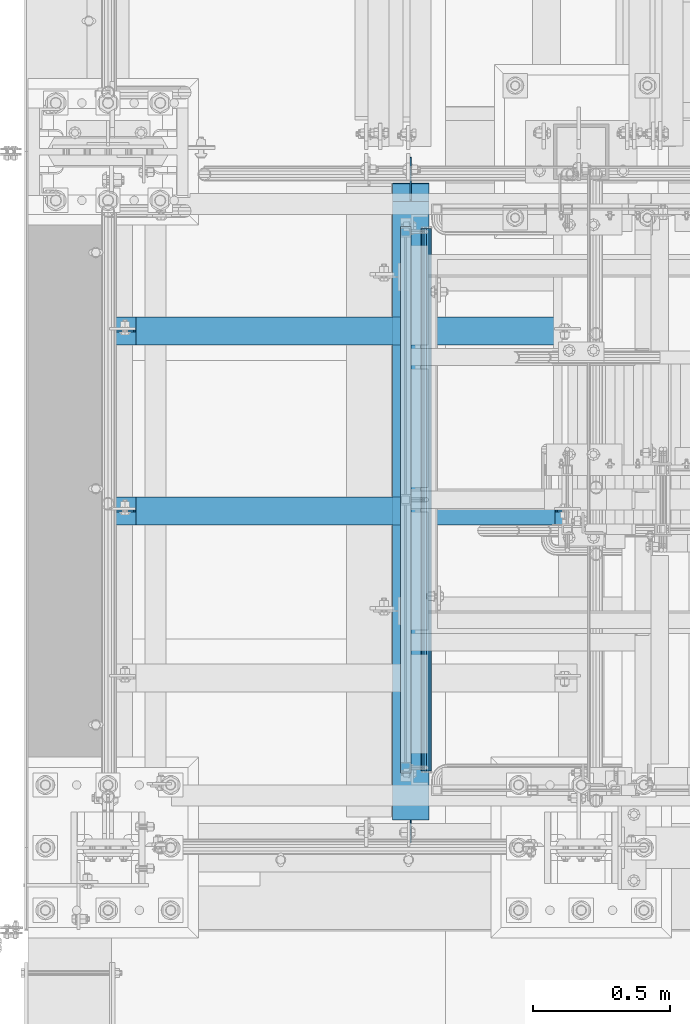
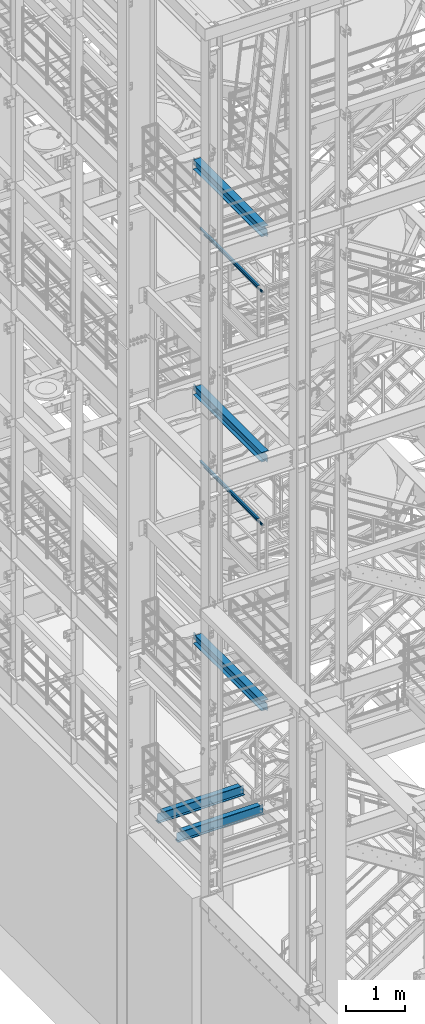
# One storey, part 954 of 1876: 9 beams, 7 elements without a shape of their own.
"""IFC2X3 building model written with IfcOpenShell, lengths in millimetres."""

from ifc_helpers import new_model, si_unit, frame, origin_with_axes, place, context, subcontext, project, spatial, faceted_brep, material, type_object, element, aggregate, save


model = new_model("IFC2X3")

# Units and contexts
model_context = context("Model", 3, precision=1e-05, world=origin_with_axes())
body_context = subcontext(model_context, "Body", "Model", "MODEL_VIEW")
ifc_project = project(units=[si_unit("LENGTHUNIT", "METRE", prefix="MILLI"), si_unit("AREAUNIT", "SQUARE_METRE"), si_unit("VOLUMEUNIT", "CUBIC_METRE"), si_unit("MASSUNIT", "GRAM", prefix="KILO"), si_unit("TIMEUNIT", "SECOND"), si_unit("PLANEANGLEUNIT", "RADIAN"), si_unit("SOLIDANGLEUNIT", "STERADIAN"), si_unit("THERMODYNAMICTEMPERATUREUNIT", "DEGREE_CELSIUS"), si_unit("LUMINOUSINTENSITYUNIT", "LUMEN")], contexts=[model_context])

# Site, building, storey
site_placement = place(None, origin_with_axes())
site = spatial("IfcSite", under=ifc_project, at=site_placement, CompositionType="ELEMENT")
building_placement = place(site_placement, origin_with_axes())
building = spatial("IfcBuilding", under=site, at=building_placement, Name="Undefined", CompositionType="ELEMENT")
storey_placement = place(building_placement, origin_with_axes())
storey = spatial("IfcBuildingStorey", under=building, at=storey_placement, Name="Undefined", CompositionType="ELEMENT", Elevation=0.0)

# Assembly, beam
assembly_1_placement = place(storey_placement, origin_with_axes())
assembly_1 = element("IfcElementAssembly", 1, at=assembly_1_placement, inside=storey, Name="BEAM", AssemblyPlace="NOTDEFINED", PredefinedType="RIGID_FRAME")
ifc_material_1 = material(Name="STEEL/A992")
beam_type_1 = type_object("IfcBeamType", Name="W8X15", PredefinedType="NOTDEFINED")
beam_1_placement = place(assembly_1_placement, frame((0.0, -5226.05, 5027.6125), z_axis=(0.0, 0.0, 1.0), x_axis=(1.0, 0.0, 0.0)))
beam_1 = element("IfcBeam", 2, at=beam_1_placement, type_object=beam_type_1, material=ifc_material_1, Name="BEAM", ObjectType="W8X15", context=body_context, shape_type="Brep", body=[
    faceted_brep([(88.8999971389772, -3.17500000000018, 71.4375000000018), (88.8999971389772, 3.17500000000018, 71.4375000000018), (17.4624999999998, 3.17500000000018, 71.4375000000018), (17.4624999999998, -3.17500000000018, 71.4375000000018), (93.7600766570227, -3.17500000000018, 72.4042299225894), (93.7600766570227, 3.17500000000018, 72.4042299225894), (97.8802531251764, -3.17500000000018, 75.1572438230678), (97.8802531251764, 3.17500000000018, 75.1572438230678), (100.633267025654, -3.17500000000018, 79.2774202912215), (100.633267025654, 3.17500000000018, 79.2774202912215), (101.599996948242, -3.17500000000018, 84.137499809267), (101.599996948242, 3.17500000000018, 84.137499809267), (101.599996948242, -50.8000000000002, 103.1875), (101.599996948242, 50.8000000000002, 103.1875), (101.599996948242, 50.8000000000002, 95.25), (101.599996948242, 3.17500000000018, 95.25), (101.599996948242, -3.17500000000018, 95.25), (101.599996948242, -50.8000000000002, 95.25), (17.4624999999998, -3.17500000000018, -95.25), (17.4624999999998, -50.8000000000002, -95.25), (1711.325, -50.8000000000002, -95.25), (1711.325, -3.17500000000018, -95.25), (17.4624999999998, -50.8000000000002, -103.1875), (1711.325, -50.8000000000002, -103.1875), (17.4624999999998, 50.8000000000002, -103.1875), (1711.325, 50.8000000000002, -103.1875), (17.4624999999998, 50.8000000000002, -95.25), (1711.325, 50.8000000000002, -95.25), (17.4624999999998, 3.17500000000018, -95.25), (1711.325, 3.17500000000018, -95.25), (1711.325, 3.17500000000018, 74.6125000000002), (1711.325, -3.17500000000018, 74.6125000000002), (1644.64999980926, 3.17500000000018, 74.6125000000002), (1644.64999980926, -3.17500000000018, 74.6125000000002), (1639.78992029122, 3.17500000000018, 75.5792299225877), (1639.78992029122, -3.17500000000018, 75.5792299225877), (1635.66974382307, 3.17500000000018, 78.3322438230662), (1635.66974382307, -3.17500000000018, 78.3322438230662), (1632.91672992259, 3.17500000000018, 82.4524202912198), (1632.91672992259, -3.17500000000018, 82.4524202912198), (1631.95, 3.17500000000018, 87.3124998092653), (1631.95, -3.17500000000018, 87.3124998092653), (1631.95, -50.8000000000002, 103.1875), (1631.95, -50.8000000000002, 95.25), (1631.95, -3.17500000000018, 95.25), (1631.95, 3.17500000000018, 95.25), (1631.95, 50.8000000000002, 95.25), (1631.95, 50.8000000000002, 103.1875)], [[[0, 1, 2, 3]], [[4, 5, 1, 0]], [[6, 7, 5, 4]], [[8, 9, 7, 6]], [[10, 11, 9, 8]], [[12, 13, 14, 15, 11, 10, 16, 17]], [[18, 19, 20, 21]], [[19, 22, 23, 20]], [[22, 24, 25, 23]], [[24, 26, 27, 25]], [[26, 28, 29, 27]], [[21, 20, 23, 25, 27, 29, 30, 31]], [[31, 30, 32, 33]], [[33, 32, 34, 35]], [[35, 34, 36, 37]], [[37, 36, 38, 39]], [[39, 38, 40, 41]], [[42, 43, 44, 41, 40, 45, 46, 47]], [[43, 42, 12, 17]], [[44, 43, 17, 16]], [[8, 6, 4, 0, 3, 18, 21, 31, 33, 35, 37, 39, 41, 44, 16, 10]], [[28, 26, 24, 22, 19, 18, 3, 2]], [[45, 40, 38, 36, 34, 32, 30, 29, 28, 2, 1, 5, 7, 9, 11, 15]], [[46, 45, 15, 14]], [[47, 46, 14, 13]], [[42, 47, 13, 12]]]),
])
aggregate(assembly_1, [beam_1])

assembly_2_placement = place(storey_placement, origin_with_axes())
assembly_2 = element("IfcElementAssembly", 3, at=assembly_2_placement, inside=storey, Name="BEAM", AssemblyPlace="NOTDEFINED", PredefinedType="RIGID_FRAME")
beam_2_placement = place(assembly_2_placement, frame((0.0, -5883.275, 5027.6125), z_axis=(0.0, 0.0, 1.0), x_axis=(1.0, 0.0, 0.0)))
beam_2 = element("IfcBeam", 4, at=beam_2_placement, type_object=beam_type_1, material=ifc_material_1, Name="BEAM", ObjectType="W8X15", context=body_context, shape_type="Brep", body=[
    faceted_brep([(88.8999971389772, -3.17500000000018, 71.4375000000018), (88.8999971389772, 3.17500000000018, 71.4375000000018), (17.4624999999998, 3.17500000000018, 71.4375000000018), (17.4624999999998, -3.17500000000018, 71.4375000000018), (93.7600766570227, -3.17500000000018, 72.4042299225894), (93.7600766570227, 3.17500000000018, 72.4042299225894), (97.8802531251764, -3.17500000000018, 75.1572438230678), (97.8802531251764, 3.17500000000018, 75.1572438230678), (100.633267025654, -3.17500000000018, 79.2774202912215), (100.633267025654, 3.17500000000018, 79.2774202912215), (101.599996948242, -3.17500000000018, 84.137499809267), (101.599996948242, 3.17500000000018, 84.137499809267), (101.599996948242, -50.8000000000002, 103.1875), (101.599996948242, 50.8000000000002, 103.1875), (101.599996948242, 50.8000000000002, 95.25), (101.599996948242, 3.17500000000018, 95.25), (101.599996948242, -3.17500000000018, 95.25), (101.599996948242, -50.8000000000002, 95.25), (17.4624999999998, -3.17500000000018, -95.25), (17.4624999999998, -50.8000000000002, -95.25), (1711.325, -50.8000000000002, -95.25), (1711.325, -3.17500000000018, -95.25), (17.4624999999998, -50.8000000000002, -103.1875), (1711.325, -50.8000000000002, -103.1875), (17.4624999999998, 50.8000000000002, -103.1875), (1711.325, 50.8000000000002, -103.1875), (17.4624999999998, 50.8000000000002, -95.25), (1711.325, 50.8000000000002, -95.25), (17.4624999999998, 3.17500000000018, -95.25), (1711.325, 3.17500000000018, -95.25), (1711.325, 3.17500000000018, 74.6125000000002), (1711.325, -3.17500000000018, 74.6125000000002), (1644.64999980926, 3.17500000000018, 74.6125000000002), (1644.64999980926, -3.17500000000018, 74.6125000000002), (1639.78992029122, 3.17500000000018, 75.5792299225877), (1639.78992029122, -3.17500000000018, 75.5792299225877), (1635.66974382307, 3.17500000000018, 78.3322438230662), (1635.66974382307, -3.17500000000018, 78.3322438230662), (1632.91672992259, 3.17500000000018, 82.4524202912198), (1632.91672992259, -3.17500000000018, 82.4524202912198), (1631.95, 3.17500000000018, 87.3124998092653), (1631.95, -3.17500000000018, 87.3124998092653), (1631.95, -50.8000000000002, 103.1875), (1631.95, -50.8000000000002, 95.25), (1631.95, -3.17500000000018, 95.25), (1631.95, 3.17500000000018, 95.25), (1631.95, 50.8000000000002, 95.25), (1631.95, 50.8000000000002, 103.1875)], [[[0, 1, 2, 3]], [[4, 5, 1, 0]], [[6, 7, 5, 4]], [[8, 9, 7, 6]], [[10, 11, 9, 8]], [[12, 13, 14, 15, 11, 10, 16, 17]], [[18, 19, 20, 21]], [[19, 22, 23, 20]], [[22, 24, 25, 23]], [[24, 26, 27, 25]], [[26, 28, 29, 27]], [[21, 20, 23, 25, 27, 29, 30, 31]], [[31, 30, 32, 33]], [[33, 32, 34, 35]], [[35, 34, 36, 37]], [[37, 36, 38, 39]], [[39, 38, 40, 41]], [[42, 43, 44, 41, 40, 45, 46, 47]], [[43, 42, 12, 17]], [[44, 43, 17, 16]], [[8, 6, 4, 0, 3, 18, 21, 31, 33, 35, 37, 39, 41, 44, 16, 10]], [[28, 26, 24, 22, 19, 18, 3, 2]], [[45, 40, 38, 36, 34, 32, 30, 29, 28, 2, 1, 5, 7, 9, 11, 15]], [[46, 45, 15, 14]], [[47, 46, 14, 13]], [[42, 47, 13, 12]]]),
])
aggregate(assembly_2, [beam_2])

assembly_3_placement = place(storey_placement, origin_with_axes())
assembly_3 = element("IfcElementAssembly", 5, at=assembly_3_placement, inside=storey, Name="RAIL", AssemblyPlace="NOTDEFINED", PredefinedType="RIGID_FRAME")
ifc_material_2 = material()
beam_type_2 = type_object("IfcBeamType", Name="HSS1-1/2X1-1/2X1/8", PredefinedType="NOTDEFINED")
beam_3_placement = place(assembly_3_placement, frame((1085.85000034225, -6838.95000038326, 11807.8249999981), z_axis=(0.0, 0.0, -1.0), x_axis=(0.0, 1.0, 0.0)))
beam_3 = element("IfcBeam", 6, at=beam_3_placement, type_object=beam_type_2, material=ifc_material_2, Name="RAIL", ObjectType="HSS1-1/2X1-1/2X1/8", context=body_context, shape_type="Brep", body=[
    faceted_brep([(3.17499995199978, 15.8749992829999, -15.8749992829999), (3.17499995199978, -15.8749992829999, -15.8749992829999), (1990.72499852089, -15.8749992830001, -15.8749992829999), (1990.72499852089, 15.8749992830001, -15.8749992829999), (34.9249985179995, -15.8749992829999, 15.8749992829999), (1958.97499995489, -15.8749992830001, 15.8749992829999), (34.9249985179995, 15.8749992829999, 15.8749992829999), (1958.97499995489, 15.8749992830001, 15.8749992829999), (0.0, 19.0499992349996, -19.0499992350001), (38.0999984699993, 19.0499992349996, 19.0499992350001), (1955.80000000289, 19.0499992350001, 19.0499992349996), (1993.8999984729, 19.0499992350001, -19.0499992349996), (38.0999984699993, -19.0499992349996, 19.0499992350001), (1955.80000000289, -19.0499992350001, 19.0499992349996), (0.0, -19.0499992349996, -19.0499992350001), (1993.8999984729, -19.0499992350001, -19.0499992349996)], [[[0, 1, 2, 3]], [[1, 4, 5, 2]], [[4, 6, 7, 5]], [[6, 0, 3, 7]], [[8, 9, 10, 11]], [[9, 12, 13, 10]], [[12, 14, 15, 13]], [[14, 8, 11, 15]], [[13, 15, 11, 10], [5, 7, 3, 2]], [[14, 12, 9, 8], [6, 4, 1, 0]]]),
])

# Assembly, beams
assembly_4_placement = place(storey_placement, origin_with_axes())
assembly_4 = element("IfcElementAssembly", 7, at=assembly_4_placement, inside=storey, Name="RAIL", AssemblyPlace="NOTDEFINED", PredefinedType="RIGID_FRAME")
beam_4_placement = place(assembly_4_placement, frame((1085.84999999374, -6838.95000038376, 16636.176851748), z_axis=(0.0, 0.0, -1.0), x_axis=(0.0, 1.0, 0.0)))
beam_4 = element("IfcBeam", 8, at=beam_4_placement, type_object=beam_type_2, material=ifc_material_2, Name="RAIL", ObjectType="HSS1-1/2X1-1/2X1/8", context=body_context, shape_type="Brep", body=[
    faceted_brep([(3.17499995199978, 15.8749992829999, -15.8749992829999), (3.17499995199978, -15.8749992829999, -15.8749992829999), (1990.72499852089, -15.8749992830001, -15.8749992829999), (1990.72499852089, 15.8749992830001, -15.8749992829999), (34.9249985179995, -15.8749992829999, 15.8749992829999), (1958.97499995489, -15.8749992830001, 15.8749992829999), (34.9249985179995, 15.8749992829999, 15.8749992829999), (1958.97499995489, 15.8749992830001, 15.8749992829999), (0.0, 19.0499992349996, -19.0499992350001), (38.0999984699993, 19.0499992349996, 19.0499992350001), (1955.80000000289, 19.0499992350001, 19.0499992349996), (1993.8999984729, 19.0499992350001, -19.0499992349996), (38.0999984699993, -19.0499992349996, 19.0499992350001), (1955.80000000289, -19.0499992350001, 19.0499992349996), (0.0, -19.0499992349996, -19.0499992350001), (1993.8999984729, -19.0499992350001, -19.0499992349996)], [[[0, 1, 2, 3]], [[1, 4, 5, 2]], [[4, 6, 7, 5]], [[6, 0, 3, 7]], [[8, 9, 10, 11]], [[9, 12, 13, 10]], [[12, 14, 15, 13]], [[14, 8, 11, 15]], [[13, 15, 11, 10], [5, 7, 3, 2]], [[14, 12, 9, 8], [6, 4, 1, 0]]]),
])
beam_type_3 = type_object("IfcBeamType", PredefinedType="NOTDEFINED")
beam_5_placement = place(assembly_4_placement, frame((1162.04999999374, -6838.94997749681, 16483.6816052369), z_axis=(0.0, 0.0, 1.0), x_axis=(0.0, 1.0, 0.0)))
beam_5 = element("IfcBeam", 9, at=beam_5_placement, type_object=beam_type_3, material=ifc_material_2, context=body_context, shape_type="Brep", body=[
    faceted_brep([(6.35000000000127, -15.875, 0.0), (6.35000000000127, -13.7481532850779, 7.9375), (1987.54997558594, -13.7481532850779, 7.9375), (1987.54997558594, -15.875, 0.0), (6.35000000000127, -7.9375, 13.7481532850798), (1987.54997558594, -7.9375, 13.7481532850798), (6.35000000000127, 0.0, 15.875), (1987.54997558594, 0.0, 15.875), (6.35000000000127, 7.9375, 13.7481532850798), (1987.54997558594, 7.9375, 13.7481532850798), (6.35000000000127, 13.7481532850779, 7.9375), (1987.54997558594, 13.7481532850779, 7.9375), (6.35000000000127, 15.875, 0.0), (1987.54997558594, 15.875, 0.0), (6.35000000000127, 13.7481532850779, -7.9375), (1987.54997558594, 13.7481532850779, -7.9375), (6.35000000000127, 7.9375, -13.7481532850798), (1987.54997558594, 7.9375, -13.7481532850798), (6.35000000000127, 0.0, -15.875), (1987.54997558594, 0.0, -15.875), (6.35000000000127, -7.9375, -13.7481532850798), (1987.54997558594, -7.9375, -13.7481532850798), (6.35000000000127, -13.7481532850779, -7.9375), (1987.54997558594, -13.7481532850779, -7.9375), (6.35000000000127, -19.05, 0.0), (6.35000000000127, -16.4977839420935, -9.52500000000146), (1987.54997558594, -16.4977839420935, -9.52500000000146), (1987.54997558594, -19.05, 0.0), (6.35000000000127, -9.52500000000009, -16.4977839420935), (1987.54997558594, -9.52500000000009, -16.4977839420935), (6.35000000000127, 0.0, -19.0499999999993), (1987.54997558594, 0.0, -19.0499999999993), (6.35000000000127, 9.52500000000009, -16.4977839420935), (1987.54997558594, 9.52500000000009, -16.4977839420935), (6.35000000000127, 16.4977839420935, -9.52500000000146), (1987.54997558594, 16.4977839420935, -9.52500000000146), (6.35000000000127, 19.05, 0.0), (1987.54997558594, 19.05, 0.0), (6.35000000000127, 16.4977839420935, 9.52500000000146), (1987.54997558594, 16.4977839420935, 9.52500000000146), (6.35000000000127, 9.52500000000009, 16.4977839420935), (1987.54997558594, 9.52500000000009, 16.4977839420935), (6.35000000000127, 0.0, 19.0499999999993), (1987.54997558594, 0.0, 19.0499999999993), (6.35000000000127, -9.52500000000009, 16.4977839420935), (1987.54997558594, -9.52500000000009, 16.4977839420935), (6.35000000000127, -16.4977839420935, 9.52500000000146), (1987.54997558594, -16.4977839420935, 9.52500000000146)], [[[0, 1, 2, 3]], [[1, 4, 5, 2]], [[4, 6, 7, 5]], [[6, 8, 9, 7]], [[8, 10, 11, 9]], [[10, 12, 13, 11]], [[12, 14, 15, 13]], [[14, 16, 17, 15]], [[16, 18, 19, 17]], [[18, 20, 21, 19]], [[20, 22, 23, 21]], [[22, 0, 3, 23]], [[24, 25, 26, 27]], [[25, 28, 29, 26]], [[28, 30, 31, 29]], [[30, 32, 33, 31]], [[32, 34, 35, 33]], [[34, 36, 37, 35]], [[36, 38, 39, 37]], [[38, 40, 41, 39]], [[40, 42, 43, 41]], [[42, 44, 45, 43]], [[44, 46, 47, 45]], [[46, 24, 27, 47]], [[29, 31, 33, 35, 37, 39, 41, 43, 45, 47, 27, 26], [5, 7, 9, 11, 13, 15, 17, 19, 21, 23, 3, 2]], [[46, 44, 42, 40, 38, 36, 34, 32, 30, 28, 25, 24], [22, 20, 18, 16, 14, 12, 10, 8, 6, 4, 1, 0]]]),
])
aggregate(assembly_4, [beam_5, beam_4])

# Beam
beam_6_placement = place(assembly_3_placement, frame((1162.05000034225, -6838.9499774963, 11655.329753487), z_axis=(0.0, 0.0, 1.0), x_axis=(0.0, 1.0, 0.0)))
beam_6 = element("IfcBeam", 10, at=beam_6_placement, type_object=beam_type_3, material=ifc_material_2, context=body_context, shape_type="Brep", body=[
    faceted_brep([(6.35000000000127, -15.875, 0.0), (6.35000000000127, -13.7481532850779, 7.9375), (1987.54997558594, -13.7481532850779, 7.9375), (1987.54997558594, -15.875, 0.0), (6.35000000000127, -7.9375, 13.7481532850798), (1987.54997558594, -7.9375, 13.7481532850798), (6.35000000000127, 0.0, 15.875), (1987.54997558594, 0.0, 15.875), (6.35000000000127, 7.9375, 13.7481532850798), (1987.54997558594, 7.9375, 13.7481532850798), (6.35000000000127, 13.7481532850779, 7.9375), (1987.54997558594, 13.7481532850779, 7.9375), (6.35000000000127, 15.875, 0.0), (1987.54997558594, 15.875, 0.0), (6.35000000000127, 13.7481532850779, -7.9375), (1987.54997558594, 13.7481532850779, -7.9375), (6.35000000000127, 7.9375, -13.7481532850798), (1987.54997558594, 7.9375, -13.7481532850798), (6.35000000000127, 0.0, -15.875), (1987.54997558594, 0.0, -15.875), (6.35000000000127, -7.9375, -13.7481532850798), (1987.54997558594, -7.9375, -13.7481532850798), (6.35000000000127, -13.7481532850779, -7.9375), (1987.54997558594, -13.7481532850779, -7.9375), (6.35000000000127, -19.05, 0.0), (6.35000000000127, -16.4977839420935, -9.52500000000146), (1987.54997558594, -16.4977839420935, -9.52500000000146), (1987.54997558594, -19.05, 0.0), (6.35000000000127, -9.52500000000009, -16.4977839420935), (1987.54997558594, -9.52500000000009, -16.4977839420935), (6.35000000000127, 0.0, -19.0499999999993), (1987.54997558594, 0.0, -19.0499999999993), (6.35000000000127, 9.52500000000009, -16.4977839420935), (1987.54997558594, 9.52500000000009, -16.4977839420935), (6.35000000000127, 16.4977839420935, -9.52500000000146), (1987.54997558594, 16.4977839420935, -9.52500000000146), (6.35000000000127, 19.05, 0.0), (1987.54997558594, 19.05, 0.0), (6.35000000000127, 16.4977839420935, 9.52500000000146), (1987.54997558594, 16.4977839420935, 9.52500000000146), (6.35000000000127, 9.52500000000009, 16.4977839420935), (1987.54997558594, 9.52500000000009, 16.4977839420935), (6.35000000000127, 0.0, 19.0499999999993), (1987.54997558594, 0.0, 19.0499999999993), (6.35000000000127, -9.52500000000009, 16.4977839420935), (1987.54997558594, -9.52500000000009, 16.4977839420935), (6.35000000000127, -16.4977839420935, 9.52500000000146), (1987.54997558594, -16.4977839420935, 9.52500000000146)], [[[0, 1, 2, 3]], [[1, 4, 5, 2]], [[4, 6, 7, 5]], [[6, 8, 9, 7]], [[8, 10, 11, 9]], [[10, 12, 13, 11]], [[12, 14, 15, 13]], [[14, 16, 17, 15]], [[16, 18, 19, 17]], [[18, 20, 21, 19]], [[20, 22, 23, 21]], [[22, 0, 3, 23]], [[24, 25, 26, 27]], [[25, 28, 29, 26]], [[28, 30, 31, 29]], [[30, 32, 33, 31]], [[32, 34, 35, 33]], [[34, 36, 37, 35]], [[36, 38, 39, 37]], [[38, 40, 41, 39]], [[40, 42, 43, 41]], [[42, 44, 45, 43]], [[44, 46, 47, 45]], [[46, 24, 27, 47]], [[29, 31, 33, 35, 37, 39, 41, 43, 45, 47, 27, 26], [5, 7, 9, 11, 13, 15, 17, 19, 21, 23, 3, 2]], [[46, 44, 42, 40, 38, 36, 34, 32, 30, 28, 25, 24], [22, 20, 18, 16, 14, 12, 10, 8, 6, 4, 1, 0]]]),
])

aggregate(assembly_3, [beam_6, beam_3])

# Assembly, beam
assembly_5_placement = place(storey_placement, origin_with_axes())
assembly_5 = element("IfcElementAssembly", 11, at=assembly_5_placement, inside=storey, Name="BEAM", AssemblyPlace="NOTDEFINED", PredefinedType="RIGID_FRAME")
beam_type_4 = type_object("IfcBeamType", Name="W8X18", PredefinedType="NOTDEFINED")
beam_7_placement = place(assembly_5_placement, frame((1104.90000034226, -7112.0, 17880.0125), z_axis=(0.0, 0.0, 1.0), x_axis=(0.0, 1.0, 0.0)))
beam_7 = element("IfcBeam", 12, at=beam_7_placement, type_object=beam_type_4, material=ifc_material_1, Name="BEAM", ObjectType="W8X18", context=body_context, shape_type="Brep", body=[
    faceted_brep([(17.4624999999996, -3.17499999999995, -71.4375000000036), (17.4624999999996, 3.17499999999995, -71.4375000000036), (93.662500190735, 3.17499999999995, -71.4375000000036), (93.662500190735, -3.17499999999995, -71.4375000000036), (98.5225797087805, 3.17499999999995, -72.4042299225912), (98.5225797087805, -3.17499999999995, -72.4042299225912), (102.642756176934, 3.17499999999995, -75.1572438230687), (102.642756176934, -3.17499999999995, -75.1572438230687), (105.395770077413, 3.17499999999995, -79.2774202912224), (105.395770077413, -3.17499999999995, -79.2774202912224), (106.3625, -3.17499999999995, -84.1374998092688), (106.3625, 3.17499999999995, -84.1374998092688), (106.3625, 3.17499999999995, -95.25), (106.3625, 66.675, -95.25), (106.3625, 66.675, -103.1875), (106.3625, -66.675, -103.1875), (106.3625, -66.675, -95.25), (106.3625, -3.17499999999995, -95.25), (2424.90625, -66.675, -103.1875), (2424.90625, 66.675, -103.1875), (2424.90625, 66.675, -96.8374998092622), (2424.90625, -66.675, -96.8374998092622), (2412.20625, 66.675, 95.25), (2412.20625, 3.17499999999995, 95.25), (100.012500000001, 3.17499999999995, 95.25), (100.012500000001, 66.675, 95.25), (87.3125001907356, -3.17499999999995, 77.7874999999949), (87.3125001907356, 3.17499999999995, 77.7874999999949), (17.4624999999996, 3.17499999999995, 77.7874999999949), (17.4624999999996, -3.17499999999995, 77.7874999999949), (92.1725797087811, -3.17499999999995, 78.7542299225825), (92.1725797087811, 3.17499999999995, 78.7542299225825), (96.2927561769347, -3.17499999999995, 81.50724382306), (96.2927561769347, 3.17499999999995, 81.50724382306), (99.0457700774132, -3.17499999999995, 85.6274202912136), (99.0457700774132, 3.17499999999995, 85.6274202912136), (100.012500000001, -3.17499999999995, 90.48749980926), (100.012500000001, 3.17499999999995, 90.48749980926), (2412.20625, -66.675, 103.1875), (2412.20625, 66.675, 103.1875), (100.012500000001, 66.675, 103.1875), (100.012500000001, -66.675, 103.1875), (2412.20625, -66.675, 95.25), (100.012500000001, -66.675, 95.25), (2412.20625, -3.17499999999995, 95.25), (100.012500000001, -3.17499999999995, 95.25), (2412.20625, -3.17499999999995, 77.7874998092702), (2412.20625, 3.17499999999995, 77.7874998092702), (2413.17297992259, -3.17499999999995, 72.9274202912238), (2413.17297992259, 3.17499999999995, 72.9274202912238), (2415.92599382307, -3.17499999999995, 68.8072438230702), (2415.92599382307, 3.17499999999995, 68.8072438230702), (2420.04617029122, -3.17499999999995, 66.0542299225926), (2420.04617029122, 3.17499999999995, 66.0542299225926), (2424.90624980927, -3.17499999999995, 65.0875000000051), (2424.90624980927, 3.17499999999995, 65.0875000000051), (2520.15625, -3.17499999999995, 65.0875000000051), (2520.15625, 3.17499999999995, 65.0875000000051), (2520.15625, -3.17499999999995, -84.1374999999971), (2520.15625, 3.17499999999995, -84.1374999999971), (2437.60624980927, -3.17499999999995, -84.1374999999971), (2437.60624980927, 3.17499999999995, -84.1374999999971), (2432.74617029122, -3.17499999999995, -85.1042299225846), (2432.74617029122, 3.17499999999995, -85.1042299225846), (2428.62599382307, -3.17499999999995, -87.8572438230622), (2428.62599382307, 3.17499999999995, -87.8572438230622), (2425.87297992259, -3.17499999999995, -91.9774202912158), (2425.87297992259, 3.17499999999995, -91.9774202912158), (2425.22202334528, -3.17499999999995, -95.25), (2425.22202334528, -66.675, -95.25), (2425.22202334528, 66.675, -95.25), (2425.22202334528, 3.17499999999995, -95.25)], [[[0, 1, 2, 3]], [[3, 2, 4, 5]], [[5, 4, 6, 7]], [[7, 6, 8, 9]], [[10, 11, 12, 13, 14, 15, 16, 17]], [[9, 8, 11, 10]], [[18, 19, 20, 21]], [[22, 23, 24, 25]], [[26, 27, 28, 29]], [[30, 31, 27, 26]], [[32, 33, 31, 30]], [[34, 35, 33, 32]], [[36, 37, 35, 34]], [[38, 39, 40, 41]], [[42, 38, 41, 43]], [[44, 42, 43, 45]], [[41, 40, 25, 24, 37, 36, 45, 43]], [[39, 22, 25, 40]], [[38, 42, 44, 46, 47, 23, 22, 39]], [[48, 49, 47, 46]], [[50, 51, 49, 48]], [[52, 53, 51, 50]], [[54, 55, 53, 52]], [[56, 57, 55, 54]], [[57, 56, 58, 59]], [[58, 60, 61, 59]], [[62, 63, 61, 60]], [[64, 65, 63, 62]], [[66, 67, 65, 64]], [[68, 69, 21, 20, 70, 71, 67, 66]], [[69, 68, 17, 16]], [[18, 21, 69, 16, 15]], [[19, 18, 15, 14]], [[70, 20, 19, 14, 13]], [[71, 70, 13, 12]], [[6, 4, 2, 1, 28, 27, 31, 33, 35, 37, 24, 23, 47, 49, 51, 53, 55, 57, 59, 61, 63, 65, 67, 71, 12, 11, 8]], [[29, 28, 1, 0]], [[68, 66, 64, 62, 60, 58, 56, 54, 52, 50, 48, 46, 44, 45, 36, 34, 32, 30, 26, 29, 0, 3, 5, 7, 9, 10, 17]]]),
])
aggregate(assembly_5, [beam_7])

assembly_6_placement = place(storey_placement, origin_with_axes())
assembly_6 = element("IfcElementAssembly", 13, at=assembly_6_placement, inside=storey, Name="BEAM", AssemblyPlace="NOTDEFINED", PredefinedType="RIGID_FRAME")
beam_8_placement = place(assembly_6_placement, frame((1104.9000002286, -7112.0, 13206.4125), z_axis=(0.0, 0.0, 1.0), x_axis=(0.0, 1.0, 0.0)))
beam_8 = element("IfcBeam", 14, at=beam_8_placement, type_object=beam_type_4, material=ifc_material_1, Name="BEAM", ObjectType="W8X18", context=body_context, shape_type="Brep", body=[
    faceted_brep([(17.4624999999996, -3.17499999999995, -71.4375000000036), (17.4624999999996, 3.17499999999995, -71.4375000000036), (93.662500190735, 3.17499999999995, -71.4375000000036), (93.662500190735, -3.17499999999995, -71.4375000000036), (98.5225797087805, 3.17499999999995, -72.4042299225912), (98.5225797087805, -3.17499999999995, -72.4042299225912), (102.642756176934, 3.17499999999995, -75.1572438230687), (102.642756176934, -3.17499999999995, -75.1572438230687), (105.395770077413, 3.17499999999995, -79.2774202912224), (105.395770077413, -3.17499999999995, -79.2774202912224), (106.3625, -3.17499999999995, -84.1374998092688), (106.3625, 3.17499999999995, -84.1374998092688), (106.3625, 3.17499999999995, -95.25), (106.3625, 66.675, -95.25), (106.3625, 66.675, -103.1875), (106.3625, -66.675, -103.1875), (106.3625, -66.675, -95.25), (106.3625, -3.17499999999995, -95.25), (2424.1125, -66.675, -103.1875), (2424.1125, 66.675, -103.1875), (2424.1125, 66.675, -96.8374998092622), (2424.1125, -66.675, -96.8374998092622), (2360.6125, 66.675, 95.25), (2360.6125, 3.17499999999995, 95.25), (100.012500000001, 3.17499999999995, 95.25), (100.012500000001, 66.675, 95.25), (87.3125001907356, -3.17499999999995, 77.7874999999949), (87.3125001907356, 3.17499999999995, 77.7874999999949), (17.4624999999996, 3.17499999999995, 77.7874999999949), (17.4624999999996, -3.17499999999995, 77.7874999999949), (92.1725797087811, -3.17499999999995, 78.7542299225825), (92.1725797087811, 3.17499999999995, 78.7542299225825), (96.2927561769347, -3.17499999999995, 81.50724382306), (96.2927561769347, 3.17499999999995, 81.50724382306), (99.0457700774132, -3.17499999999995, 85.6274202912136), (99.0457700774132, 3.17499999999995, 85.6274202912136), (100.012500000001, -3.17499999999995, 90.48749980926), (100.012500000001, 3.17499999999995, 90.48749980926), (2360.6125, -66.675, 103.1875), (2360.6125, 66.675, 103.1875), (100.012500000001, 66.675, 103.1875), (100.012500000001, -66.675, 103.1875), (2360.6125, -66.675, 95.25), (100.012500000001, -66.675, 95.25), (2360.6125, -3.17499999999995, 95.25), (100.012500000001, -3.17499999999995, 95.25), (2360.6125, -3.17499999999995, 65.0874998092677), (2360.6125, 3.17499999999995, 65.0874998092677), (2361.57922992259, -3.17499999999995, 60.2274202912213), (2361.57922992259, 3.17499999999995, 60.2274202912213), (2364.33224382307, -3.17499999999995, 56.1072438230676), (2364.33224382307, 3.17499999999995, 56.1072438230676), (2368.45242029122, -3.17499999999995, 53.3542299225901), (2368.45242029122, 3.17499999999995, 53.3542299225901), (2373.31249980927, -3.17499999999995, 52.3875000000025), (2373.31249980927, 3.17499999999995, 52.3875000000025), (2519.3625, -3.17499999999995, 52.3875000000025), (2519.3625, 3.17499999999995, 52.3875000000025), (2519.3625, -3.17499999999995, -84.1374999999971), (2519.3625, 3.17499999999995, -84.1374999999971), (2436.81249980927, -3.17499999999995, -84.1374999999971), (2436.81249980927, 3.17499999999995, -84.1374999999971), (2431.95242029122, -3.17499999999995, -85.1042299225846), (2431.95242029122, 3.17499999999995, -85.1042299225846), (2427.83224382307, -3.17499999999995, -87.8572438230622), (2427.83224382307, 3.17499999999995, -87.8572438230622), (2425.07922992259, -3.17499999999995, -91.9774202912158), (2425.07922992259, 3.17499999999995, -91.9774202912158), (2424.42827334528, -3.17499999999995, -95.25), (2424.42827334528, -66.675, -95.25), (2424.42827334528, 66.675, -95.25), (2424.42827334528, 3.17499999999995, -95.25)], [[[0, 1, 2, 3]], [[3, 2, 4, 5]], [[5, 4, 6, 7]], [[7, 6, 8, 9]], [[10, 11, 12, 13, 14, 15, 16, 17]], [[9, 8, 11, 10]], [[18, 19, 20, 21]], [[22, 23, 24, 25]], [[26, 27, 28, 29]], [[30, 31, 27, 26]], [[32, 33, 31, 30]], [[34, 35, 33, 32]], [[36, 37, 35, 34]], [[38, 39, 40, 41]], [[42, 38, 41, 43]], [[44, 42, 43, 45]], [[41, 40, 25, 24, 37, 36, 45, 43]], [[39, 22, 25, 40]], [[38, 42, 44, 46, 47, 23, 22, 39]], [[48, 49, 47, 46]], [[50, 51, 49, 48]], [[52, 53, 51, 50]], [[54, 55, 53, 52]], [[56, 57, 55, 54]], [[57, 56, 58, 59]], [[58, 60, 61, 59]], [[62, 63, 61, 60]], [[64, 65, 63, 62]], [[66, 67, 65, 64]], [[68, 69, 21, 20, 70, 71, 67, 66]], [[69, 68, 17, 16]], [[18, 21, 69, 16, 15]], [[19, 18, 15, 14]], [[70, 20, 19, 14, 13]], [[71, 70, 13, 12]], [[6, 4, 2, 1, 28, 27, 31, 33, 35, 37, 24, 23, 47, 49, 51, 53, 55, 57, 59, 61, 63, 65, 67, 71, 12, 11, 8]], [[29, 28, 1, 0]], [[68, 66, 64, 62, 60, 58, 56, 54, 52, 50, 48, 46, 44, 45, 36, 34, 32, 30, 26, 29, 0, 3, 5, 7, 9, 10, 17]]]),
])
aggregate(assembly_6, [beam_8])

assembly_7_placement = place(storey_placement, origin_with_axes())
assembly_7 = element("IfcElementAssembly", 15, at=assembly_7_placement, inside=storey, Name="BEAM", AssemblyPlace="NOTDEFINED", PredefinedType="RIGID_FRAME")
beam_9_placement = place(assembly_7_placement, frame((1104.90000034226, -7112.0, 8050.2125), z_axis=(0.0, 0.0, 1.0), x_axis=(0.0, 1.0, 0.0)))
beam_9 = element("IfcBeam", 16, at=beam_9_placement, type_object=beam_type_4, material=ifc_material_1, Name="BEAM", ObjectType="W8X18", context=body_context, shape_type="Brep", body=[
    faceted_brep([(17.4624999999996, -3.17499999999995, -71.4375000000036), (17.4624999999996, 3.17499999999995, -71.4375000000036), (93.662500190735, 3.17499999999995, -71.4375000000036), (93.662500190735, -3.17499999999995, -71.4375000000036), (98.5225797087805, 3.17499999999995, -72.4042299225912), (98.5225797087805, -3.17499999999995, -72.4042299225912), (102.642756176934, 3.17499999999995, -75.1572438230687), (102.642756176934, -3.17499999999995, -75.1572438230687), (105.395770077413, 3.17499999999995, -79.2774202912224), (105.395770077413, -3.17499999999995, -79.2774202912224), (106.3625, -3.17499999999995, -84.1374998092688), (106.3625, 3.17499999999995, -84.1374998092688), (106.3625, 3.17499999999995, -95.25), (106.3625, 66.675, -95.25), (106.3625, 66.675, -103.1875), (106.3625, -66.675, -103.1875), (106.3625, -66.675, -95.25), (106.3625, -3.17499999999995, -95.25), (2421.73125, -66.675, -103.1875), (2421.73125, 66.675, -103.1875), (2421.73125, 66.675, -96.837499809265), (2421.73125, -66.675, -96.837499809265), (2358.23125, 66.675, 95.25), (2358.23125, 3.17499999999995, 95.25), (100.012500000001, 3.17499999999995, 95.25), (100.012500000001, 66.675, 95.25), (87.3125001907356, -3.17499999999995, 77.7874999999949), (87.3125001907356, 3.17499999999995, 77.7874999999949), (17.4624999999996, 3.17499999999995, 77.7874999999949), (17.4624999999996, -3.17499999999995, 77.7874999999949), (92.1725797087811, -3.17499999999995, 78.7542299225825), (92.1725797087811, 3.17499999999995, 78.7542299225825), (96.2927561769347, -3.17499999999995, 81.50724382306), (96.2927561769347, 3.17499999999995, 81.50724382306), (99.0457700774132, -3.17499999999995, 85.6274202912136), (99.0457700774132, 3.17499999999995, 85.6274202912136), (100.012500000001, -3.17499999999995, 90.48749980926), (100.012500000001, 3.17499999999995, 90.48749980926), (2358.23125, -66.675, 103.1875), (2358.23125, 66.675, 103.1875), (100.012500000001, 66.675, 103.1875), (100.012500000001, -66.675, 103.1875), (2358.23125, -66.675, 95.25), (100.012500000001, -66.675, 95.25), (2358.23125, -3.17499999999995, 95.25), (100.012500000001, -3.17499999999995, 95.25), (2358.23125, -3.17499999999995, 65.087499809265), (2358.23125, 3.17499999999995, 65.087499809265), (2359.19797992259, -3.17499999999995, 60.2274202912195), (2359.19797992259, 3.17499999999995, 60.2274202912195), (2361.95099382307, -3.17499999999995, 56.1072438230658), (2361.95099382307, 3.17499999999995, 56.1072438230658), (2366.07117029122, -3.17499999999995, 53.3542299225874), (2366.07117029122, 3.17499999999995, 53.3542299225874), (2370.93124980927, -3.17499999999995, 52.3874999999998), (2370.93124980927, 3.17499999999995, 52.3874999999998), (2516.98125, -3.17499999999995, 52.3874999999998), (2516.98125, 3.17499999999995, 52.3874999999998), (2516.98125, -3.17499999999995, -84.1374999999998), (2516.98125, 3.17499999999995, -84.1374999999998), (2434.43124980927, -3.17499999999995, -84.1374999999998), (2434.43124980927, 3.17499999999995, -84.1374999999998), (2429.57117029122, -3.17499999999995, -85.1042299225874), (2429.57117029122, 3.17499999999995, -85.1042299225874), (2425.45099382307, -3.17499999999995, -87.8572438230658), (2425.45099382307, 3.17499999999995, -87.8572438230658), (2422.69797992259, -3.17499999999995, -91.9774202912195), (2422.69797992259, 3.17499999999995, -91.9774202912195), (2422.04702334528, -3.17499999999995, -95.25), (2422.04702334528, -66.675, -95.25), (2422.04702334528, 66.675, -95.25), (2422.04702334528, 3.17499999999995, -95.25)], [[[0, 1, 2, 3]], [[3, 2, 4, 5]], [[5, 4, 6, 7]], [[7, 6, 8, 9]], [[10, 11, 12, 13, 14, 15, 16, 17]], [[9, 8, 11, 10]], [[18, 19, 20, 21]], [[22, 23, 24, 25]], [[26, 27, 28, 29]], [[30, 31, 27, 26]], [[32, 33, 31, 30]], [[34, 35, 33, 32]], [[36, 37, 35, 34]], [[38, 39, 40, 41]], [[42, 38, 41, 43]], [[44, 42, 43, 45]], [[41, 40, 25, 24, 37, 36, 45, 43]], [[39, 22, 25, 40]], [[38, 42, 44, 46, 47, 23, 22, 39]], [[48, 49, 47, 46]], [[50, 51, 49, 48]], [[52, 53, 51, 50]], [[54, 55, 53, 52]], [[56, 57, 55, 54]], [[57, 56, 58, 59]], [[58, 60, 61, 59]], [[62, 63, 61, 60]], [[64, 65, 63, 62]], [[66, 67, 65, 64]], [[68, 69, 21, 20, 70, 71, 67, 66]], [[69, 68, 17, 16]], [[18, 21, 69, 16, 15]], [[19, 18, 15, 14]], [[70, 20, 19, 14, 13]], [[71, 70, 13, 12]], [[6, 4, 2, 1, 28, 27, 31, 33, 35, 37, 24, 23, 47, 49, 51, 53, 55, 57, 59, 61, 63, 65, 67, 71, 12, 11, 8]], [[29, 28, 1, 0]], [[68, 66, 64, 62, 60, 58, 56, 54, 52, 50, 48, 46, 44, 45, 36, 34, 32, 30, 26, 29, 0, 3, 5, 7, 9, 10, 17]]]),
])
aggregate(assembly_7, [beam_9])

save(model, "model.ifc")
